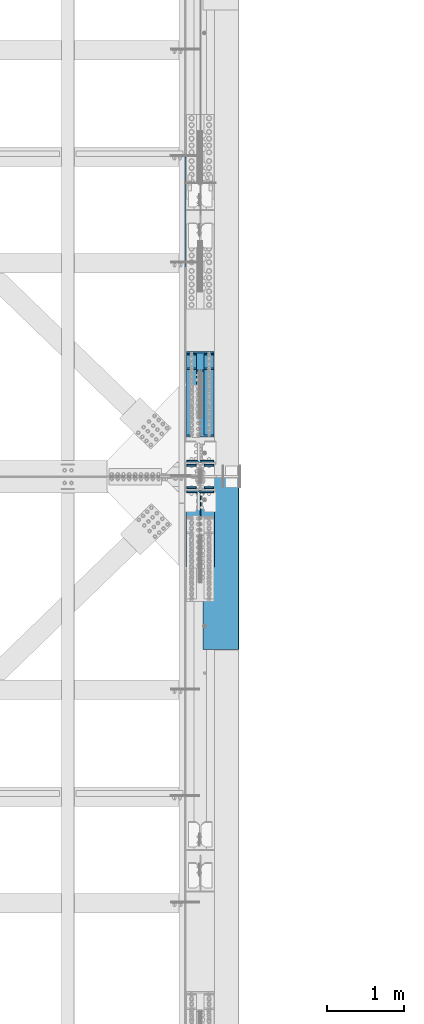
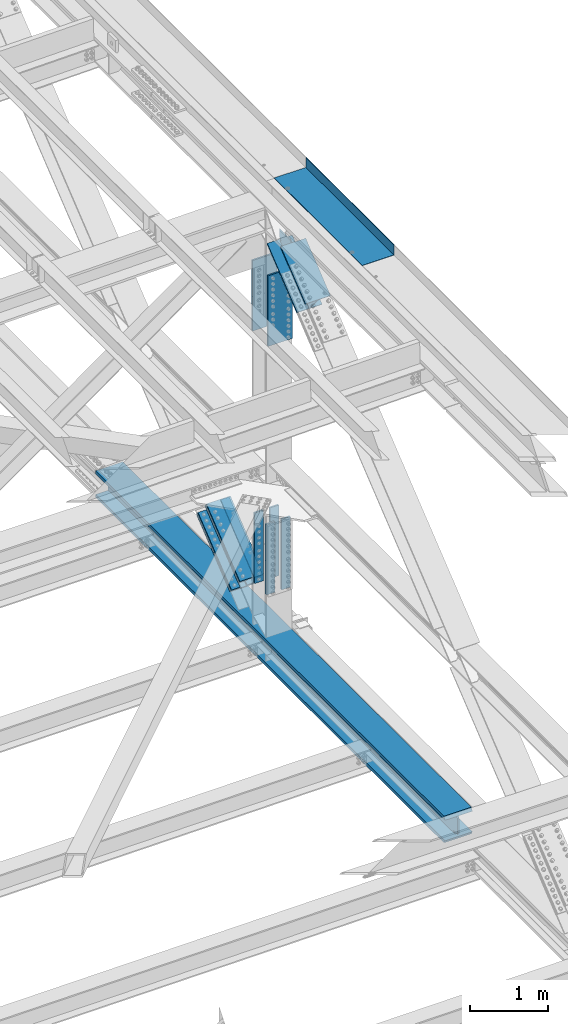
# One storey, part 1978 of 3843: 8 beams, 7 members, 3 elements without a shape of their own.
"""IFC2X3 building model written with IfcOpenShell, lengths in millimetres."""

from ifc_helpers import new_model, si_unit, frame, origin_with_axes, place, context, subcontext, project, spatial, faceted_brep, material, type_object, element, aggregate, save


model = new_model("IFC2X3")

# Units and contexts
model_context = context("Model", 3, precision=1e-05, world=origin_with_axes())
body_context = subcontext(model_context, "Body", "Model", "MODEL_VIEW")
ifc_project = project(units=[si_unit("LENGTHUNIT", "METRE", prefix="MILLI"), si_unit("AREAUNIT", "SQUARE_METRE"), si_unit("VOLUMEUNIT", "CUBIC_METRE"), si_unit("MASSUNIT", "GRAM", prefix="KILO"), si_unit("TIMEUNIT", "SECOND"), si_unit("PLANEANGLEUNIT", "RADIAN"), si_unit("SOLIDANGLEUNIT", "STERADIAN"), si_unit("THERMODYNAMICTEMPERATUREUNIT", "DEGREE_CELSIUS"), si_unit("LUMINOUSINTENSITYUNIT", "LUMEN")], contexts=[model_context])

# Site, building, storey
site_placement = place(None, origin_with_axes())
site = spatial("IfcSite", under=ifc_project, at=site_placement, CompositionType="ELEMENT")
building_placement = place(site_placement, origin_with_axes())
building = spatial("IfcBuilding", under=site, at=building_placement, Name="Undefined", CompositionType="ELEMENT")
storey_placement = place(building_placement, origin_with_axes())
storey = spatial("IfcBuildingStorey", under=building, at=storey_placement, Name="Undefined", CompositionType="ELEMENT", Elevation=0.0)

# Assembly, beam, members
assembly_1_placement = place(storey_placement, origin_with_axes())
assembly_1 = element("IfcElementAssembly", 1, at=assembly_1_placement, inside=storey, Name="BEAM", AssemblyPlace="NOTDEFINED", PredefinedType="RIGID_FRAME")
ifc_material_1 = material(Name="STEEL/A992")
beam_type_1 = type_object("IfcBeamType", Name="W14X257", PredefinedType="NOTDEFINED")
beam_1_placement = place(assembly_1_placement, frame((85648.8, 62484.0000113843, 39551.5028835539), z_axis=(0.0, 0.00134533200005535, 0.999999095040495), x_axis=(0.0, 0.999999095040495, -0.00134533200005457)))
beam_1 = element("IfcBeam", 2, at=beam_1_placement, type_object=beam_type_1, material=ifc_material_1, Name="BEAM", ObjectType="W14X257", context=body_context, shape_type="Brep", body=[
    faceted_brep([(4.80343998169701, 15.0812500000029, -125.806260757199), (22.2659350334434, -15.0812500000029, -125.792719131307), (22.117637588075, -15.0812500000029, 125.821414125348), (4.65513969414314, 15.0812500000029, 125.812694793953), (31.8393535147989, 203.199999999997, -207.941081691664), (31.8393535147989, -203.199999999997, -207.941081691664), (4.82379025999398, -203.199999999997, -160.334283955708), (4.82379025999398, -15.0812500000029, -160.334283955708), (4.82379025999398, 15.0812500000029, -160.334283955708), (4.82379025999398, 203.199999999997, -160.334283955708), (31.5942184782543, -203.199999999997, 207.9833597459), (31.594209543633, 203.199999999997, 207.983846391631), (4.6347894496721, 203.199999999997, 160.3406605993), (4.6347894496721, 15.0812500000029, 160.3406605993), (4.6347894496721, -15.0812500000029, 160.3406605993), (4.6347894496721, -203.199999999997, 160.3406605993), (99.0191347804794, 15.0812500000029, -125.73319939409), (99.0191347804794, -15.0812500000029, -125.73319939409), (103.870391829383, 15.0812500000029, -127.056822235885), (103.870391829383, -15.0812500000029, -127.056822235885), (107.371585077795, 15.0812500000029, -130.666298405522), (107.371585077795, -15.0812500000029, -130.666298405522), (70.8792746573818, -15.0812500000029, -160.289751645731), (70.8792746573818, 15.0812500000029, -160.289751645731), (103.349028717974, -15.0812500000029, -143.745925267627), (103.349028717974, 15.0812500000029, -143.745925267627), (107.068693119385, -15.0812500000029, -140.362026758106), (107.068693119385, 15.0812500000029, -140.362026758106), (108.546876291366, -15.0812500000029, -135.555609496587), (108.546876291366, 15.0812500000029, -135.555609496587), (896.70175639043, -203.199999999997, -207.358021542139), (896.70175639043, 203.199999999997, -207.358021542139), (1793.24781432665, 203.199999999997, -206.887916995038), (1793.24781432665, -203.199999999997, -206.887916995038), (2689.79393263013, 203.199999999997, -206.552128025483), (2689.79393263013, -203.199999999997, -206.552128025483), (3586.34009117844, 203.199999999997, -206.35065463998), (3586.34009117844, -203.199999999997, -206.35065463998), (4482.88626984917, 203.199999999997, -206.283496844109), (4482.88626984917, -203.199999999997, -206.283496844109), (5379.4324485199, 203.199999999997, -206.350654637899), (5379.4324485199, -203.199999999997, -206.350654637899), (6275.97860706822, 203.199999999997, -206.552128021314), (6275.97860706822, -203.199999999997, -206.552128021314), (7172.52472537168, 203.199999999997, -206.887916988802), (7172.52472537168, -203.199999999997, -206.887916988802), (8069.07078330789, 203.199999999997, -207.358021533815), (8069.07078330789, -203.199999999997, -207.358021533815), (8959.26674739494, 203.199999999997, -207.958160687071), (8959.26674739494, -203.199999999997, -207.958160687071), (8959.3024239518, -203.199999999997, -160.333174049934), (8069.0993229626, -203.199999999997, -159.733030085226), (7172.54613011325, -203.199999999997, -159.262921799018), (6275.99287689618, -203.199999999997, -158.927130159253), (5379.43958343394, -203.199999999997, -158.725655172457), (4482.88626984911, -203.199999999997, -158.658496844226), (3586.3329562643, -203.199999999997, -158.725655174538), (2689.77966280205, -203.199999999997, -158.927130163422), (1793.22640958497, -203.199999999997, -159.262921805253), (896.673216735624, -203.199999999997, -159.73303009355), (70.8792746573818, -203.199999999997, -160.289751645731), (70.8792746573818, 203.199999999997, -160.289751645731), (896.673216735624, 203.199999999997, -159.73303009355), (1793.22640958497, 203.199999999997, -159.262921805253), (2689.77966280205, 203.199999999997, -158.927130163422), (3586.3329562643, 203.199999999997, -158.725655174538), (4482.88626984911, 203.199999999997, -158.658496844226), (5379.43958343394, 203.199999999997, -158.725655172457), (6275.99287689618, 203.199999999997, -158.927130159253), (7172.54613011325, 203.199999999997, -159.262921799018), (8069.0993229626, 203.199999999997, -159.733030085226), (8959.3024239518, 203.199999999997, -160.333174049934), (896.673216735624, 15.0812500000029, -159.73303009355), (1793.22640958497, 15.0812500000029, -159.262921805253), (2689.77966280205, 15.0812500000029, -158.927130163422), (3586.3329562643, 15.0812500000029, -158.725655174538), (4482.88626984911, 15.0812500000029, -158.658496844226), (5379.43958343394, 15.0812500000029, -158.725655172457), (6275.99287689618, 15.0812500000029, -158.927130159253), (7172.54613011325, 15.0812500000029, -159.262921799018), (8069.0993229626, 15.0812500000029, -159.733030085226), (8959.3024239518, 15.0812500000029, -160.333174049934), (8069.29148997093, -203.199999999997, 160.941912335242), (8069.29148997093, -15.0812500000029, 160.941912335242), (8959.54264610124, -15.0812500000029, 160.34173597343), (8959.54264610124, -203.199999999997, 160.34173597343), (7172.69025537318, -203.199999999997, 161.412045812176), (7172.69025537318, -15.0812500000029, 161.412045812176), (6276.08896040445, -203.199999999997, 161.747855445319), (6276.08896040445, -15.0812500000029, 161.747855445319), (5379.48762518843, -203.199999999997, 161.949341228137), (5379.48762518843, -15.0812500000029, 161.949341228137), (4482.88626984875, -203.199999999997, 162.016503155042), (4482.88626984875, -15.0812500000029, 162.016503155042), (3586.28491450904, -203.199999999997, 161.949341226049), (3586.28491450904, -15.0812500000029, 161.949341226049), (2689.68357929302, -203.199999999997, 161.74785544115), (2689.68357929302, -15.0812500000029, 161.74785544115), (1793.08228432431, -203.199999999997, 161.412045805933), (1793.08228432431, -15.0812500000029, 161.412045805933), (896.481049726564, -203.199999999997, 160.941912326918), (896.481049726564, -15.0812500000029, 160.941912326918), (70.6717354354332, -15.0812500000029, 160.385180411329), (70.6717354354332, -203.199999999997, 160.385180411329), (896.452510071744, -203.199999999997, 208.5669037755), (896.452510071744, 203.199999999997, 208.5669037755), (1793.06087958263, -203.199999999997, 209.037040995718), (1793.06087958263, 203.199999999997, 209.037040995718), (2689.66930946495, -203.199999999997, 209.372853303212), (2689.66930946495, 203.199999999997, 209.372853303212), (3586.27777959491, -203.199999999997, 209.574340691492), (3586.27777959491, 203.199999999997, 209.574340691492), (4482.88626984869, -203.199999999997, 209.64150315494), (4482.88626984869, 203.199999999997, 209.64150315494), (5379.49476010246, -203.199999999997, 209.574340693573), (5379.49476010246, 203.199999999997, 209.574340693573), (6276.10323023242, -203.199999999997, 209.372853307381), (6276.10323023242, 203.199999999997, 209.372853307381), (7172.71166011474, -203.199999999997, 209.03704100196), (7172.71166011474, 203.199999999997, 209.03704100196), (8069.32002962561, -203.199999999997, 208.566903783831), (8069.32002962561, 203.199999999997, 208.566903783831), (8959.5783226581, -203.199999999997, 207.966722610567), (8959.5783226581, 203.199999999997, 207.966722610567), (8959.54264610124, 203.199999999997, 160.34173597343), (8069.29148997093, 203.199999999997, 160.941912335242), (7172.69025537318, 203.199999999997, 161.412045812176), (6276.08896040445, 203.199999999997, 161.747855445319), (5379.48762518843, 203.199999999997, 161.949341228137), (4482.88626984875, 203.199999999997, 162.016503155042), (3586.28491450904, 203.199999999997, 161.949341226049), (2689.68357929302, 203.199999999997, 161.74785544115), (1793.08228432431, 203.199999999997, 161.412045805933), (896.481049726564, 203.199999999997, 160.941912326918), (70.6717354354332, 203.199999999997, 160.385180411329), (8069.29148997093, 15.0812500000029, 160.941912335242), (8959.54264610124, 15.0812500000029, 160.34173597343), (7172.69025537318, 15.0812500000029, 161.412045812176), (6276.08896040445, 15.0812500000029, 161.747855445319), (5379.48762518843, 15.0812500000029, 161.949341228137), (4482.88626984875, 15.0812500000029, 162.016503155042), (3586.28491450904, 15.0812500000029, 161.949341226049), (2689.68357929302, 15.0812500000029, 161.74785544115), (1793.08228432431, 15.0812500000029, 161.412045805933), (896.481049726564, 15.0812500000029, 160.941912326918), (70.6717354354332, 15.0812500000029, 160.385180411329), (98.8556291930945, -15.0812500000029, 125.859730750133), (98.8556291930945, 15.0812500000029, 125.859730750133), (103.705194946531, -15.0812500000029, 127.189536895668), (103.705194946531, 15.0812500000029, 127.189536895668), (107.201783992175, -15.0812500000029, 130.803473451189), (107.201783992175, 15.0812500000029, 130.803473451189), (108.370841360236, -15.0812500000029, 135.694278829833), (108.370841360236, 15.0812500000029, 135.694278829833), (106.886532171848, -15.0812500000029, 140.498807798918), (106.886532171848, 15.0812500000029, 140.498807798918), (103.162557001328, -15.0812500000029, 143.877961733095), (103.162557001328, 15.0812500000029, 143.877961733095), (8959.3024239518, -15.0812500000029, -160.333174049934), (8069.0993229626, -15.0812500000029, -159.733030085226), (7172.54613011325, -15.0812500000029, -159.262921799018), (6275.99287689618, -15.0812500000029, -158.927130159253), (5379.43958343394, -15.0812500000029, -158.725655172457), (4482.88626984911, -15.0812500000029, -158.658496844226), (3586.3329562643, -15.0812500000029, -158.725655174538), (2689.77966280205, -15.0812500000029, -158.927130163422), (1793.22640958497, -15.0812500000029, -159.262921805253), (896.673216735624, -15.0812500000029, -159.73303009355)], [[[0, 1, 2, 3]], [[4, 5, 6, 7, 8, 9]], [[10, 11, 12, 13, 14, 15]], [[16, 17, 1, 0]], [[17, 16, 18, 19]], [[19, 18, 20, 21]], [[22, 23, 8, 7]], [[24, 25, 23, 22]], [[26, 27, 25, 24]], [[28, 29, 27, 26]], [[21, 20, 29, 28]], [[30, 31, 32, 33]], [[33, 32, 34, 35]], [[35, 34, 36, 37]], [[37, 36, 38, 39]], [[39, 38, 40, 41]], [[41, 40, 42, 43]], [[43, 42, 44, 45]], [[45, 44, 46, 47]], [[47, 46, 48, 49]], [[30, 33, 35, 37, 39, 41, 43, 45, 47, 49, 50, 51, 52, 53, 54, 55, 56, 57, 58, 59, 60, 6, 5]], [[31, 30, 5, 4]], [[61, 62, 63, 64, 65, 66, 67, 68, 69, 70, 71, 48, 46, 44, 42, 40, 38, 36, 34, 32, 31, 4, 9]], [[62, 72, 73, 63]], [[63, 73, 74, 64]], [[64, 74, 75, 65]], [[65, 75, 76, 66]], [[66, 76, 77, 67]], [[67, 77, 78, 68]], [[68, 78, 79, 69]], [[69, 79, 80, 70]], [[70, 80, 81, 71]], [[82, 83, 84, 85]], [[86, 87, 83, 82]], [[88, 89, 87, 86]], [[90, 91, 89, 88]], [[92, 93, 91, 90]], [[94, 95, 93, 92]], [[96, 97, 95, 94]], [[98, 99, 97, 96]], [[100, 101, 99, 98]], [[102, 101, 100, 103, 15, 14]], [[104, 105, 11, 10]], [[105, 104, 106, 107]], [[107, 106, 108, 109]], [[109, 108, 110, 111]], [[111, 110, 112, 113]], [[113, 112, 114, 115]], [[115, 114, 116, 117]], [[117, 116, 118, 119]], [[119, 118, 120, 121]], [[121, 120, 122, 123]], [[105, 107, 109, 111, 113, 115, 117, 119, 121, 123, 124, 125, 126, 127, 128, 129, 130, 131, 132, 133, 134, 12, 11]], [[135, 125, 124, 136]], [[137, 126, 125, 135]], [[138, 127, 126, 137]], [[139, 128, 127, 138]], [[140, 129, 128, 139]], [[141, 130, 129, 140]], [[142, 131, 130, 141]], [[143, 132, 131, 142]], [[144, 133, 132, 143]], [[134, 133, 144, 145, 13, 12]], [[146, 147, 3, 2]], [[148, 149, 147, 146]], [[150, 151, 149, 148]], [[152, 153, 151, 150]], [[154, 155, 153, 152]], [[156, 157, 155, 154]], [[102, 145, 157, 156]], [[14, 13, 145, 102]], [[103, 100, 98, 96, 94, 92, 90, 88, 86, 82, 85, 122, 120, 118, 116, 114, 112, 110, 108, 106, 104, 10, 15]], [[84, 158, 50, 49, 48, 71, 81, 136, 124, 123, 122, 85]], [[159, 51, 50, 158]], [[160, 52, 51, 159]], [[161, 53, 52, 160]], [[162, 54, 53, 161]], [[163, 55, 54, 162]], [[164, 56, 55, 163]], [[165, 57, 56, 164]], [[166, 58, 57, 165]], [[167, 59, 58, 166]], [[60, 59, 167, 22, 7, 6]], [[23, 72, 62, 61, 9, 8]], [[18, 16, 0, 3, 147, 149, 151, 153, 155, 157, 145, 144, 143, 142, 141, 140, 139, 138, 137, 135, 136, 81, 80, 79, 78, 77, 76, 75, 74, 73, 72, 23, 25, 27, 29, 20]], [[17, 19, 21, 28, 26, 24, 22, 167, 166, 165, 164, 163, 162, 161, 160, 159, 158, 84, 83, 87, 89, 91, 93, 95, 97, 99, 101, 102, 156, 154, 152, 150, 148, 146, 2, 1]]]),
])
ifc_material_2 = material(Name="STEEL/A572-50")
member_type_1 = type_object("IfcMemberType", PredefinedType="NOTDEFINED")
member_1_placement = place(assembly_1_placement, frame((85534.5, 68867.0296074926, 40646.144836479), z_axis=(1.0, 0.0, 0.0), x_axis=(0.0, -0.777700934239515, -0.628634438193602)))
member_1 = element("IfcMember", 3, at=member_1_placement, type_object=member_type_1, material=ifc_material_2, Name="PLATE", context=body_context, shape_type="Brep", body=[
    faceted_brep([(-4.36557456851006e-11, 12.7000000000116, -63.5), (-4.36557456851006e-11, 12.7000000000116, 63.5), (1104.90000001677, 12.7000000017251, 63.5), (1104.90000001677, 12.7000000017251, -63.5), (1.45519152283669e-11, -12.700000000008, 63.5), (1104.90000001682, -12.6999999982909, 63.5), (1.45519152283669e-11, -12.700000000008, -63.5), (1104.90000001682, -12.6999999982909, -63.5)], [[[0, 1, 2, 3]], [[1, 4, 5, 2]], [[4, 6, 7, 5]], [[6, 0, 3, 7]], [[5, 7, 3, 2]], [[6, 4, 1, 0]]]),
])
member_2_placement = place(assembly_1_placement, frame((85534.5, 68681.4424459797, 40875.7398126942), z_axis=(1.0, 0.0, 0.0), x_axis=(0.0, -0.777700934239515, -0.628634438193602)))
member_2 = element("IfcMember", 4, at=member_2_placement, type_object=member_type_1, material=ifc_material_2, Name="PLATE", context=body_context, shape_type="Brep", body=[
    faceted_brep([(-4.36557456851006e-11, 12.7000000000116, -63.5), (-4.36557456851006e-11, 12.7000000000116, 63.5), (1104.90000001677, 12.7000000017251, 63.5), (1104.90000001677, 12.7000000017251, -63.5), (1.45519152283669e-11, -12.700000000008, 63.5), (1104.90000001682, -12.6999999982909, 63.5), (1.45519152283669e-11, -12.700000000008, -63.5), (1104.90000001682, -12.6999999982909, -63.5)], [[[0, 1, 2, 3]], [[1, 4, 5, 2]], [[4, 6, 7, 5]], [[6, 0, 3, 7]], [[5, 7, 3, 2]], [[6, 4, 1, 0]]]),
])
member_3_placement = place(assembly_1_placement, frame((85763.1, 68867.0407664854, 40646.1310313825), z_axis=(1.0, 0.0, 0.0), x_axis=(0.0, -0.777700934239515, -0.628634438193602)))
member_3 = element("IfcMember", 5, at=member_3_placement, type_object=member_type_1, material=ifc_material_2, Name="PLATE", context=body_context, shape_type="Brep", body=[
    faceted_brep([(-4.36557456851006e-11, 12.7000000000116, -63.5), (-4.36557456851006e-11, 12.7000000000116, 63.5), (1104.90000001677, 12.7000000017251, 63.5), (1104.90000001677, 12.7000000017251, -63.5), (1.45519152283669e-11, -12.700000000008, 63.5), (1104.90000001682, -12.6999999982909, 63.5), (1.45519152283669e-11, -12.700000000008, -63.5), (1104.90000001682, -12.6999999982909, -63.5)], [[[0, 1, 2, 3]], [[1, 4, 5, 2]], [[4, 6, 7, 5]], [[6, 0, 3, 7]], [[5, 7, 3, 2]], [[6, 4, 1, 0]]]),
])
member_4_placement = place(assembly_1_placement, frame((85763.1, 68681.4429957298, 40875.7391325832), z_axis=(1.0, 0.0, 0.0), x_axis=(0.0, -0.777700934239515, -0.628634438193602)))
member_4 = element("IfcMember", 6, at=member_4_placement, type_object=member_type_1, material=ifc_material_2, Name="PLATE", context=body_context, shape_type="Brep", body=[
    faceted_brep([(-4.36557456851006e-11, 12.7000000000116, -63.5), (-4.36557456851006e-11, 12.7000000000116, 63.5), (1104.90000001677, 12.7000000017251, 63.5), (1104.90000001677, 12.7000000017251, -63.5), (1.45519152283669e-11, -12.700000000008, 63.5), (1104.90000001682, -12.6999999982909, 63.5), (1.45519152283669e-11, -12.700000000008, -63.5), (1104.90000001682, -12.6999999982909, -63.5)], [[[0, 1, 2, 3]], [[1, 4, 5, 2]], [[4, 6, 7, 5]], [[6, 0, 3, 7]], [[5, 7, 3, 2]], [[6, 4, 1, 0]]]),
])
member_type_2 = type_object("IfcMemberType", PredefinedType="NOTDEFINED")
member_5_placement = place(assembly_1_placement, frame((85648.8, 68035.7235201767, 39916.9571697302), z_axis=(1.0, 0.0, 0.0), x_axis=(0.0, 0.777700934239509, 0.628634438193609)))
member_5 = element("IfcMember", 7, at=member_5_placement, type_object=member_type_2, material=ifc_material_2, Name="PLATE", context=body_context, shape_type="Brep", body=[
    faceted_brep([(-1.45519152283669e-11, 12.7000000000025, -177.800000000003), (-1.45519152283669e-11, 12.7000000000025, 177.800000000003), (1104.90000001682, 12.7000000017051, 177.800000000003), (1104.90000001682, 12.7000000017051, -177.800000000003), (4.36557456851006e-11, -12.7000000000171, 177.800000000003), (1104.90000001686, -12.6999999983072, 177.800000000003), (4.36557456851006e-11, -12.7000000000171, -177.800000000003), (1104.90000001686, -12.6999999983072, -177.800000000003)], [[[0, 1, 2, 3]], [[1, 4, 5, 2]], [[4, 6, 7, 5]], [[6, 0, 3, 7]], [[5, 7, 3, 2]], [[6, 4, 1, 0]]]),
])
member_6_placement = place(assembly_1_placement, frame((85648.8, 67794.1714566558, 40215.787863768), z_axis=(1.0, 0.0, 0.0), x_axis=(0.0, 0.777700934239509, 0.628634438193609)))
member_6 = element("IfcMember", 8, at=member_6_placement, type_object=member_type_2, material=ifc_material_2, Name="PLATE", context=body_context, shape_type="Brep", body=[
    faceted_brep([(-1.45519152283669e-11, 12.7000000000025, -177.800000000003), (-1.45519152283669e-11, 12.7000000000025, 177.800000000003), (1104.90000001682, 12.7000000017051, 177.800000000003), (1104.90000001682, 12.7000000017051, -177.800000000003), (4.36557456851006e-11, -12.7000000000171, 177.800000000003), (1104.90000001686, -12.6999999983072, 177.800000000003), (4.36557456851006e-11, -12.7000000000171, -177.800000000003), (1104.90000001686, -12.6999999983072, -177.800000000003)], [[[0, 1, 2, 3]], [[1, 4, 5, 2]], [[4, 6, 7, 5]], [[6, 0, 3, 7]], [[5, 7, 3, 2]], [[6, 4, 1, 0]]]),
])

# Assembly, member
assembly_2_placement = place(storey_placement, origin_with_axes())
assembly_2 = element("IfcElementAssembly", 9, at=assembly_2_placement, inside=storey, Name="BEAM", AssemblyPlace="NOTDEFINED", PredefinedType="RIGID_FRAME")
member_type_3 = type_object("IfcMemberType", Name="W14X99", PredefinedType="NOTDEFINED")
member_7_placement = place(assembly_2_placement, frame((85648.8, 66201.1269422077, 45451.8427855118), z_axis=(0.0, -0.62928248312701, 0.777176657156856), x_axis=(0.0, 0.77717665715686, 0.629282483127005)))
member_7 = element("IfcMember", 10, at=member_7_placement, type_object=member_type_3, material=ifc_material_1, Name="BEAM", ObjectType="W14X99", context=body_context, shape_type="Brep", body=[
    faceted_brep([(6.35000000674336, 185.737500000003, -160.33750000099), (6.35000000674336, 6.35000000000582, -160.33750000099), (989.733103112972, 6.35000000000582, -160.337500000037), (989.733103112972, 185.737500000003, -160.337500000037), (968.720325485527, -6.35000000000582, -160.015917254589), (968.720325485527, 6.35000000000582, -160.015917254589), (958.545907517298, 6.35000000000582, -146.841330895243), (958.545907517298, -6.35000000000582, -146.841330895243), (956.607525364394, 6.35000000000582, -141.974289672929), (956.607525364394, -6.35000000000582, -141.974289672929), (957.536036522157, 6.35000000000582, -136.818391820939), (957.536036522157, -6.35000000000582, -136.818391820939), (961.050556988033, 6.35000000000582, -132.93334851045), (961.050556988033, -6.35000000000582, -132.93334851045), (966.087908826899, 6.35000000000582, -131.494424579104), (966.087908826899, -6.35000000000582, -131.494424579104), (1012.08032123129, 6.35000000000582, -131.510680568658), (1028.41170590036, -6.35000000000582, -131.516452886418), (1098.64116029014, -6.35000000000582, -44.7125994076041), (1080.81232584827, 6.35000000000582, -46.5576802938149), (861.96957302888, 6.35000000000582, 131.97852111749), (882.096871818067, -6.35000000000582, 131.948469798693), (798.342238363664, 6.35000000000582, 132.07352071671), (798.342238363664, -6.35000000000582, 132.07352071671), (793.304541455858, 6.35000000000582, 133.523626494186), (793.304541455858, -6.35000000000582, 133.523626494186), (789.797093284506, 6.35000000000582, 137.419650650497), (789.797093284506, -6.35000000000582, 137.419650650497), (788.882315646522, 6.35000000000582, 142.581469978461), (788.882315646522, -6.35000000000582, 142.581469978461), (790.837298795115, 6.35000000000582, 147.445546230957), (790.837298795115, -6.35000000000582, 147.445546230957), (6.35000000639411, -185.737500000003, 160.337500001014), (6.35000000639411, -6.35000000000582, 160.337500001014), (800.862316835075, -6.35000000000582, 160.337500001792), (800.862316835075, -185.737500000003, 160.337500001792), (6.35000000674336, -185.737500000003, -179.387500001117), (6.35000000674336, 185.737500000003, -179.387500001117), (989.708496152612, 185.737500000003, -179.387500000164), (989.708496152612, -185.737500000003, -179.387500000164), (6.35000000674336, -185.737500000003, -160.33750000099), (989.733103112972, -185.737500000003, -160.337500000037), (6.35000000674336, -6.35000000000582, -160.33750000099), (989.733103112972, -6.35000000000582, -160.337500000037), (989.733747853737, -6.35000000000582, -159.838360273766), (989.733885900714, 6.35000000000582, -159.997713275668), (6.35000000639411, 6.35000000000582, 160.337500001014), (800.862316835075, 6.35000000000582, 160.337500001792), (6.35000000636501, -185.737500000003, 179.387500001133), (6.35000000636501, 185.737500000003, 179.387500001133), (6.35000000639411, 185.737500000003, 160.337500001014), (800.862316835075, 185.737500000003, 160.337500001792), (801.239426024957, 185.737500000003, 160.822454165777), (801.239426024957, -185.737500000003, 160.822454165777), (823.47156361799, 185.737500000003, 160.738371126689), (823.47156361799, -185.737500000003, 160.738371126689), (823.49565278583, -185.737500000003, 179.387500001926), (823.49565278583, 185.737500000003, 179.387500001926)], [[[0, 1, 2, 3]], [[4, 5, 6, 7]], [[7, 6, 8, 9]], [[9, 8, 10, 11]], [[11, 10, 12, 13]], [[13, 12, 14, 15]], [[15, 14, 16, 17]], [[18, 17, 16, 19]], [[20, 21, 18, 19]], [[22, 23, 21, 20]], [[23, 22, 24, 25]], [[25, 24, 26, 27]], [[27, 26, 28, 29]], [[29, 28, 30, 31]], [[32, 33, 34, 35]], [[36, 37, 38, 39]], [[40, 36, 39, 41]], [[42, 40, 41, 43]], [[4, 7, 9, 11, 13, 15, 17, 18, 21, 23, 25, 27, 29, 31, 34, 33, 42, 43, 44]], [[5, 4, 44, 45]], [[1, 46, 47, 30, 28, 26, 24, 22, 20, 19, 16, 14, 12, 10, 8, 6, 5, 45, 2]], [[44, 43, 41, 39, 38, 3, 2, 45]], [[37, 0, 3, 38]], [[36, 40, 42, 33, 32, 48, 49, 50, 46, 1, 0, 37]], [[46, 50, 51, 47]], [[35, 34, 31, 30, 47, 51, 52, 53]], [[53, 52, 54, 55]], [[48, 32, 35, 53, 55, 56]], [[49, 48, 56, 57]], [[52, 51, 50, 49, 57, 54]], [[56, 55, 54, 57]]]),
])

# Beam
beam_type_2 = type_object("IfcBeamType", PredefinedType="NOTDEFINED")
beam_2_placement = place(assembly_1_placement, frame((85763.1, 67124.2626920286, 41526.2285612007), z_axis=(-1.0, 0.0, 0.0), x_axis=(0.0, 0.0, -1.0)))
beam_2 = element("IfcBeam", 11, at=beam_2_placement, type_object=beam_type_2, material=ifc_material_2, Name="PLATE", context=body_context, shape_type="Brep", body=[
    faceted_brep([(-4.36557456851006e-11, 12.7000000000116, -63.5), (-4.36557456851006e-11, 12.7000000000116, 63.5), (1104.90000001677, 12.7000000017251, 63.5), (1104.90000001677, 12.7000000017251, -63.5), (1.45519152283669e-11, -12.700000000008, 63.5), (1104.90000001682, -12.6999999982909, 63.5), (1.45519152283669e-11, -12.700000000008, -63.5), (1104.90000001682, -12.6999999982909, -63.5)], [[[0, 1, 2, 3]], [[1, 4, 5, 2]], [[4, 6, 7, 5]], [[6, 0, 3, 7]], [[5, 7, 3, 2]], [[6, 4, 1, 0]]]),
])

beam_3_placement = place(assembly_1_placement, frame((85763.1, 67419.5376184277, 41526.2285325581), z_axis=(-1.0, 0.0, 0.0), x_axis=(0.0, 0.0, -1.0)))
beam_3 = element("IfcBeam", 12, at=beam_3_placement, type_object=beam_type_2, material=ifc_material_2, Name="PLATE", context=body_context, shape_type="Brep", body=[
    faceted_brep([(-4.36557456851006e-11, 12.7000000000116, -63.5), (-4.36557456851006e-11, 12.7000000000116, 63.5), (1104.90000001677, 12.7000000017251, 63.5), (1104.90000001677, 12.7000000017251, -63.5), (1.45519152283669e-11, -12.700000000008, 63.5), (1104.90000001682, -12.6999999982909, 63.5), (1.45519152283669e-11, -12.700000000008, -63.5), (1104.90000001682, -12.6999999982909, -63.5)], [[[0, 1, 2, 3]], [[1, 4, 5, 2]], [[4, 6, 7, 5]], [[6, 0, 3, 7]], [[5, 7, 3, 2]], [[6, 4, 1, 0]]]),
])

beam_4_placement = place(assembly_1_placement, frame((85534.5, 67124.2626920286, 41526.2285612007), z_axis=(-1.0, 0.0, 0.0), x_axis=(0.0, 0.0, -1.0)))
beam_4 = element("IfcBeam", 13, at=beam_4_placement, type_object=beam_type_2, material=ifc_material_2, Name="PLATE", context=body_context, shape_type="Brep", body=[
    faceted_brep([(-4.36557456851006e-11, 12.7000000000116, -63.5), (-4.36557456851006e-11, 12.7000000000116, 63.5), (1104.90000001677, 12.7000000017251, 63.5), (1104.90000001677, 12.7000000017251, -63.5), (1.45519152283669e-11, -12.700000000008, 63.5), (1104.90000001682, -12.6999999982909, 63.5), (1.45519152283669e-11, -12.700000000008, -63.5), (1104.90000001682, -12.6999999982909, -63.5)], [[[0, 1, 2, 3]], [[1, 4, 5, 2]], [[4, 6, 7, 5]], [[6, 0, 3, 7]], [[5, 7, 3, 2]], [[6, 4, 1, 0]]]),
])

beam_5_placement = place(assembly_1_placement, frame((85534.5, 67419.5376184277, 41526.2285325581), z_axis=(-1.0, 0.0, 0.0), x_axis=(0.0, 0.0, -1.0)))
beam_5 = element("IfcBeam", 14, at=beam_5_placement, type_object=beam_type_2, material=ifc_material_2, Name="PLATE", context=body_context, shape_type="Brep", body=[
    faceted_brep([(-4.36557456851006e-11, 12.7000000000116, -63.5), (-4.36557456851006e-11, 12.7000000000116, 63.5), (1104.90000001677, 12.7000000017251, 63.5), (1104.90000001677, 12.7000000017251, -63.5), (1.45519152283669e-11, -12.700000000008, 63.5), (1104.90000001682, -12.6999999982909, 63.5), (1.45519152283669e-11, -12.700000000008, -63.5), (1104.90000001682, -12.6999999982909, -63.5)], [[[0, 1, 2, 3]], [[1, 4, 5, 2]], [[4, 6, 7, 5]], [[6, 0, 3, 7]], [[5, 7, 3, 2]], [[6, 4, 1, 0]]]),
])

aggregate(assembly_1, [beam_1, member_1, member_2, member_3, member_4, member_5, member_6, beam_2, beam_3, beam_4, beam_5])

beam_type_3 = type_object("IfcBeamType", PredefinedType="NOTDEFINED")
beam_6_placement = place(assembly_2_placement, frame((85648.8, 67073.4625000013, 45444.2959599931), z_axis=(1.0, 0.0, 0.0), x_axis=(0.0, 0.0, -1.0)))
beam_6 = element("IfcBeam", 15, at=beam_6_placement, type_object=beam_type_3, material=ifc_material_2, Name="PLATE", context=body_context, shape_type="Brep", body=[
    faceted_brep([(-1.45519152283669e-11, 12.7000000000025, -177.800000000003), (-1.45519152283669e-11, 12.7000000000025, 177.800000000003), (1104.90000001682, 12.7000000017051, 177.800000000003), (1104.90000001682, 12.7000000017051, -177.800000000003), (4.36557456851006e-11, -12.7000000000171, 177.800000000003), (1104.90000001686, -12.6999999983072, 177.800000000003), (4.36557456851006e-11, -12.7000000000171, -177.800000000003), (1104.90000001686, -12.6999999983072, -177.800000000003)], [[[0, 1, 2, 3]], [[1, 4, 5, 2]], [[4, 6, 7, 5]], [[6, 0, 3, 7]], [[5, 7, 3, 2]], [[6, 4, 1, 0]]]),
])

beam_7_placement = place(assembly_2_placement, frame((85648.8, 67470.3376380945, 45444.2959599931), z_axis=(1.0, 0.0, 0.0), x_axis=(0.0, 0.0, -1.0)))
beam_7 = element("IfcBeam", 16, at=beam_7_placement, type_object=beam_type_3, material=ifc_material_2, Name="PLATE", context=body_context, shape_type="Brep", body=[
    faceted_brep([(-1.45519152283669e-11, 12.7000000000025, -177.800000000003), (-1.45519152283669e-11, 12.7000000000025, 177.800000000003), (1104.90000001682, 12.7000000017051, 177.800000000003), (1104.90000001682, 12.7000000017051, -177.800000000003), (4.36557456851006e-11, -12.7000000000171, 177.800000000003), (1104.90000001686, -12.6999999983072, 177.800000000003), (4.36557456851006e-11, -12.7000000000171, -177.800000000003), (1104.90000001686, -12.6999999983072, -177.800000000003)], [[[0, 1, 2, 3]], [[1, 4, 5, 2]], [[4, 6, 7, 5]], [[6, 0, 3, 7]], [[5, 7, 3, 2]], [[6, 4, 1, 0]]]),
])

aggregate(assembly_2, [member_7, beam_6, beam_7])

# Assembly, beam
assembly_3_placement = place(storey_placement, origin_with_axes())
assembly_3 = element("IfcElementAssembly", 17, at=assembly_3_placement, inside=storey, Name="BEAM", AssemblyPlace="NOTDEFINED", PredefinedType="RIGID_FRAME")
ifc_material_3 = material(Name="STEEL/A36")
beam_type_4 = type_object("IfcBeamType", PredefinedType="NOTDEFINED")
beam_8_placement = place(assembly_3_placement, frame((85680.5500000019, 66141.6, 46772.5124999999), z_axis=(0.0, -1.0, 0.0), x_axis=(1.0, 0.0, 0.0)))
beam_8 = element("IfcBeam", 18, at=beam_8_placement, type_object=beam_type_4, material=ifc_material_3, Name="BENT_PLATE", context=body_context, shape_type="Brep", body=[
    faceted_brep([(466.724999999991, 4.76249999999709, -1127.12500004766), (469.899998426787, 1.58750004768081, -1130.3), (0.0, 1.58750004768081, -1130.3), (0.0, 4.76249999999709, -1127.12500004766), (466.725000000006, 160.337499999994, -1127.12500004766), (469.899998426801, 160.337499999994, -1130.3), (0.0, 4.76249999999709, 1130.3), (466.724999999991, 4.76249999999709, 1130.3), (0.0, -4.76249999999709, -1130.3), (0.0, -4.76249999999709, 1130.3), (476.249999999985, -4.76249999999709, -1130.3), (476.249999999985, -4.76249999999709, 1130.3), (466.725000000006, 160.337499999994, 1130.3), (476.25, 160.337499999994, 1130.3), (476.25, 160.337499999994, -1130.3)], [[[0, 1, 2, 3]], [[4, 5, 1, 0]], [[6, 7, 0, 3]], [[8, 9, 6, 3, 2]], [[9, 8, 10, 11]], [[7, 12, 4, 0]], [[7, 6, 9, 11, 13, 12]], [[11, 10, 14, 13]], [[5, 14, 10, 8, 2, 1]], [[12, 13, 14, 5, 4]]]),
])
aggregate(assembly_3, [beam_8])

save(model, "model.ifc")
